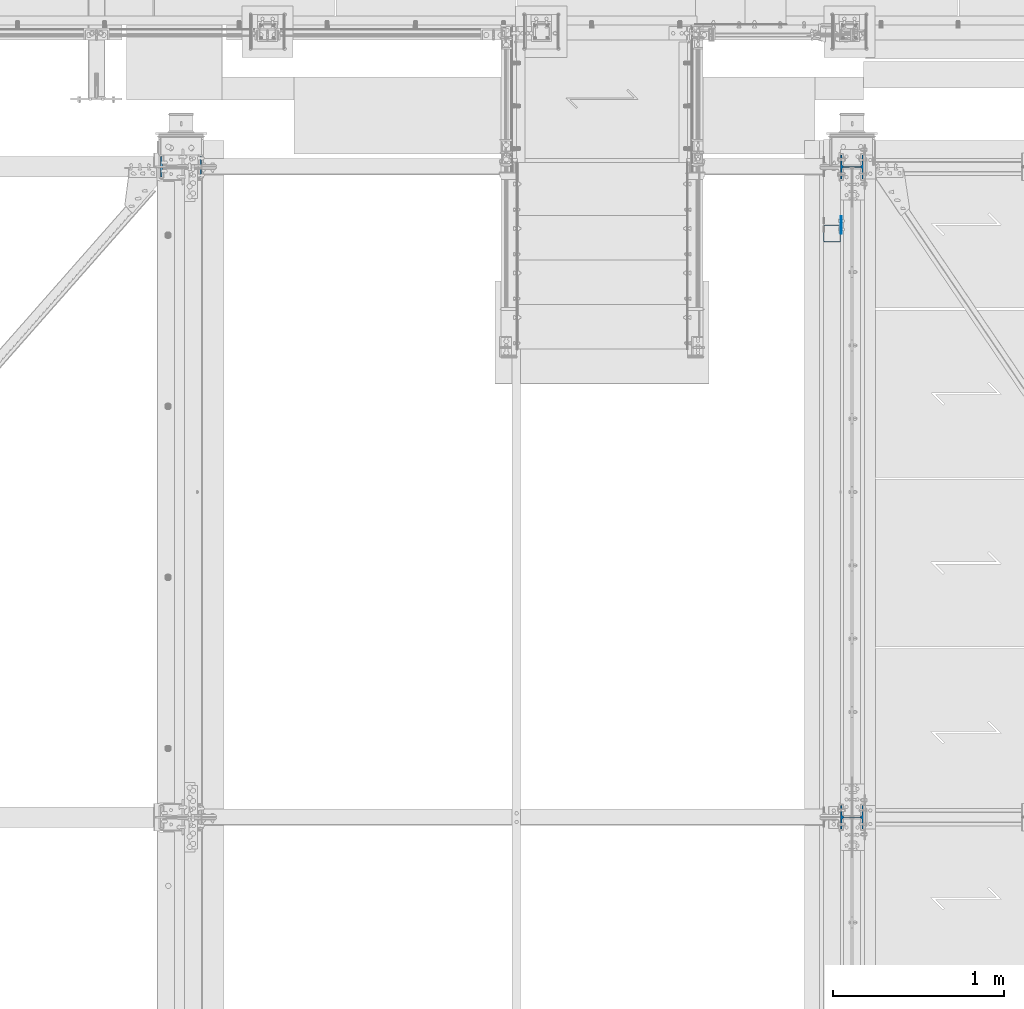
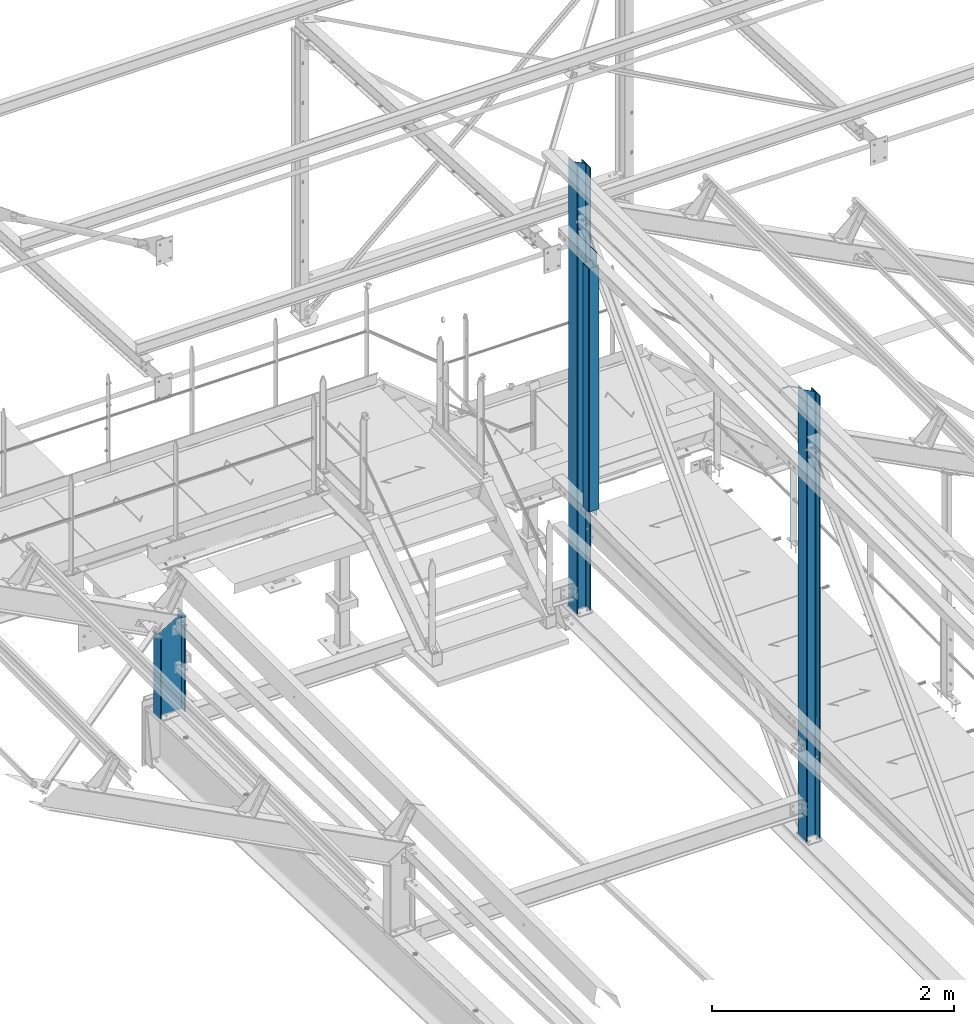
# One storey, part 12 of 496: 5 columns, 4 elements without a shape of their own.
"""IFC2X3 building model written with IfcOpenShell, lengths in millimetres."""

from ifc_helpers import new_model, si_unit, frame, origin_with_axes, origin_2d_with_axis, place, context, subcontext, project, spatial, rectangle, hollow_rectangle, i_section, extrude, clip, halfspace, material, type_object, element, aggregate, save


model = new_model("IFC2X3")

# Units and contexts
model_context = context("Model", 3, precision=1e-05, world=origin_with_axes())
body_context = subcontext(model_context, "Body", "Model", "MODEL_VIEW")
ifc_project = project(units=[si_unit("LENGTHUNIT", "METRE", prefix="MILLI"), si_unit("AREAUNIT", "SQUARE_METRE"), si_unit("VOLUMEUNIT", "CUBIC_METRE"), si_unit("MASSUNIT", "GRAM", prefix="KILO"), si_unit("TIMEUNIT", "SECOND"), si_unit("PLANEANGLEUNIT", "RADIAN"), si_unit("SOLIDANGLEUNIT", "STERADIAN"), si_unit("THERMODYNAMICTEMPERATUREUNIT", "DEGREE_CELSIUS"), si_unit("LUMINOUSINTENSITYUNIT", "LUMEN")], contexts=[model_context])

# Site, building, storey
site_placement = place(None, origin_with_axes())
site = spatial("IfcSite", under=ifc_project, at=site_placement, CompositionType="ELEMENT")
building_placement = place(site_placement, origin_with_axes())
building = spatial("IfcBuilding", under=site, at=building_placement, Name="Undefined", CompositionType="ELEMENT")
storey_placement = place(building_placement, origin_with_axes())
storey = spatial("IfcBuildingStorey", under=building, at=storey_placement, Name="Undefined", CompositionType="ELEMENT", Elevation=0.0)

# Assembly, column
assembly_1_placement = place(storey_placement, origin_with_axes())
assembly_1 = element("IfcElementAssembly", 1, at=assembly_1_placement, inside=storey, Name="MONTANT", AssemblyPlace="NOTDEFINED", PredefinedType="NOTDEFINED")
ifc_material_1 = material(Name="Undefined/S235-E24")
column_type_1 = type_object("IfcColumnType", PredefinedType="NOTDEFINED")
column_1_placement = place(assembly_1_placement, frame((23353.5000106229, 14810.0000783974, 8555.00000000001), z_axis=(0.0, 0.0, 1.0), x_axis=(0.0, 1.0, 0.0)))
column_1 = element("IfcColumn", 2, at=column_1_placement, type_object=column_type_1, material=ifc_material_1, Name="MONTANT", context=body_context, shape_type="SweptSolid", body=[
    extrude(hollow_rectangle(XDim=100.0, YDim=100.0, WallThickness=4.0, InnerFilletRadius=4.0, OuterFilletRadius=8.0, at=origin_2d_with_axis()), frame((0.0, 0.0, 2460.0), z_axis=(0.0, 0.0, -1.0), x_axis=(0.0, 1.0, 0.0)), (0.0, 0.0, 1.0), 2460.0),
])

assembly_2_placement = place(storey_placement, origin_with_axes())
assembly_2 = element("IfcElementAssembly", 3, at=assembly_2_placement, inside=storey, Name="MONTANT", AssemblyPlace="NOTDEFINED", PredefinedType="NOTDEFINED")
ifc_material_2 = material(Name="Undefined/S275-E28")
column_type_2 = type_object("IfcColumnType", Name="HEA140", PredefinedType="NOTDEFINED")
column_2_placement = place(assembly_2_placement, frame((23470.0, 15200.0, 7260.0), z_axis=(0.0, 0.0, 1.0), x_axis=(-1.0, 0.0, 0.0)))
column_2 = element("IfcColumn", 4, at=column_2_placement, type_object=column_type_2, material=ifc_material_2, Name="MONTANT", ObjectType="HEA140", context=body_context, shape_type="Clipping", body=[
    clip(extrude(i_section(OverallWidth=140.0, OverallDepth=133.0, WebThickness=5.5, FlangeThickness=8.5, FilletRadius=12.0, at=origin_2d_with_axis()), frame((0.0, 0.0, 4551.40988027575), z_axis=(0.0, 0.0, -1.0), x_axis=(0.0, 1.0, 0.0)), (0.0, 0.0, 1.0), 4551.41), halfspace(frame((-66.5, 70.0, 4471.22657322575), z_axis=(-0.460093242228747, -7.1029704621934e-09, 0.887870603441425), x_axis=(0.887870603441425, 0.0, 0.460093242228747)), False)),
])
aggregate(assembly_2, [column_2])

assembly_3_placement = place(storey_placement, origin_with_axes())
assembly_3 = element("IfcElementAssembly", 5, at=assembly_3_placement, inside=storey, Name="MONTANT", AssemblyPlace="NOTDEFINED", PredefinedType="NOTDEFINED")
column_3_placement = place(assembly_3_placement, frame((23470.0, 11400.0, 7260.0), z_axis=(0.0, 0.0, 1.0), x_axis=(-1.0, 0.0, 0.0)))
column_3 = element("IfcColumn", 6, at=column_3_placement, type_object=column_type_2, material=ifc_material_2, Name="MONTANT", ObjectType="HEA140", context=body_context, shape_type="Clipping", body=[
    clip(extrude(i_section(OverallWidth=140.0, OverallDepth=133.0, WebThickness=5.5, FlangeThickness=8.5, FilletRadius=12.0, at=origin_2d_with_axis()), frame((0.0, 0.0, 4551.40988027575), z_axis=(0.0, 0.0, -1.0), x_axis=(0.0, 1.0, 0.0)), (0.0, 0.0, 1.0), 4551.41), halfspace(frame((-66.5, 70.0, 4471.22657322575), z_axis=(-0.460093242228747, -7.1029704621934e-09, 0.887870603441425), x_axis=(0.887870603441425, 0.0, 0.460093242228747)), False)),
])
aggregate(assembly_3, [column_3])

# Column
column_type_3 = type_object("IfcColumnType", PredefinedType="NOTDEFINED")
column_4_placement = place(assembly_1_placement, frame((23406.0000000189, 14860.0000783974, 8450.0), z_axis=(0.0, 0.0, 1.0), x_axis=(0.0, 1.0, 0.0)))
column_4 = element("IfcColumn", 7, at=column_4_placement, type_object=column_type_3, material=ifc_material_1, context=body_context, shape_type="SweptSolid", body=[
    extrude(rectangle(XDim=5.0, YDim=100.0, at=origin_2d_with_axis()), frame((0.0, 0.0, 2670.0), z_axis=(0.0, 0.0, -1.0), x_axis=(0.0, 1.0, 0.0)), (0.0, 0.0, 1.0), 2670.0),
])

aggregate(assembly_1, [column_4, column_1])

# Assembly, column
assembly_4_placement = place(storey_placement, origin_with_axes())
assembly_4 = element("IfcElementAssembly", 8, at=assembly_4_placement, inside=storey, Name="TRAVERSE SHED", AssemblyPlace="NOTDEFINED", PredefinedType="NOTDEFINED")
column_type_4 = type_object("IfcColumnType", Name="IPE240", PredefinedType="NOTDEFINED")
column_5_placement = place(assembly_4_placement, frame((19550.0, 15200.0, 7572.32075715937), z_axis=(0.0, 0.0, 1.0), x_axis=(-1.0, 0.0, 0.0)))
column_5 = element("IfcColumn", 9, at=column_5_placement, type_object=column_type_4, material=ifc_material_2, Name="TRAVERSE SHED", ObjectType="IPE240", context=body_context, shape_type="Clipping", body=[
    clip(clip(extrude(i_section(OverallWidth=120.0, OverallDepth=240.0, WebThickness=6.199999809, FlangeThickness=9.800000191, FilletRadius=15.0, at=origin_2d_with_axis()), frame((0.0, 0.0, 980.31021404363), z_axis=(0.0, 0.0, -1.0), x_axis=(0.0, 1.0, 0.0)), (0.0, 0.0, 1.0), 1045.59), halfspace(frame((-120.000000919932, 11400.0, 977.679244729961), z_axis=(0.517914825899091, 0.0, 0.855432190833332), x_axis=(0.0, 1.0, 0.0)), False)), halfspace(frame((0.0, -74.9626762494518, 7.64915511178879), z_axis=(0.0, 0.031410477145298, -0.999506569225788), x_axis=(1.0, 0.0, 0.0)), False)),
])
aggregate(assembly_4, [column_5])

save(model, "model.ifc")
